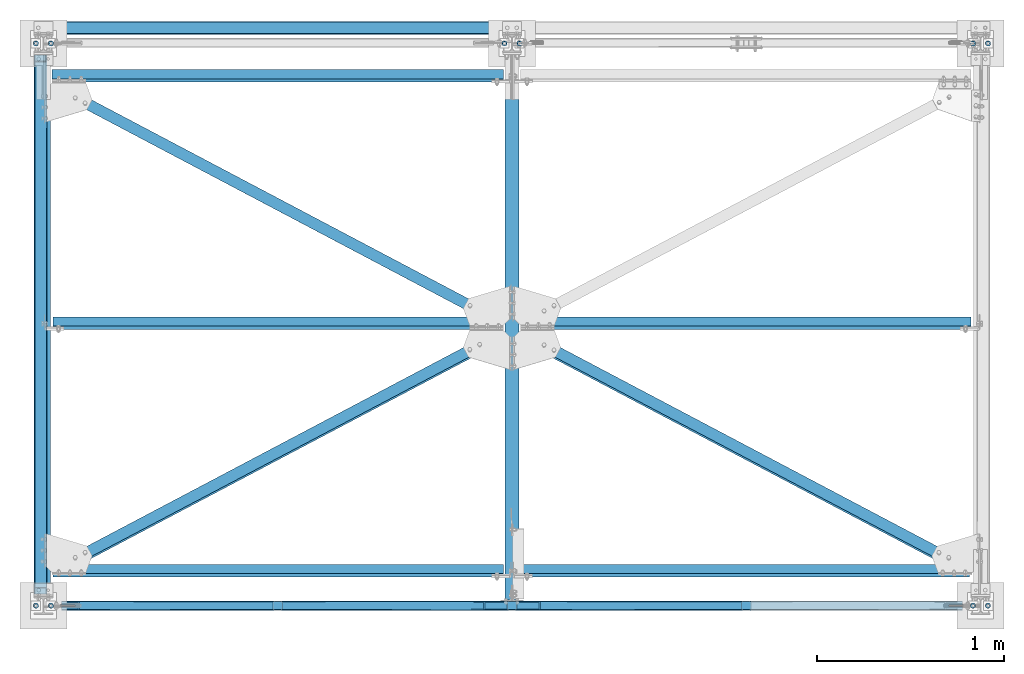
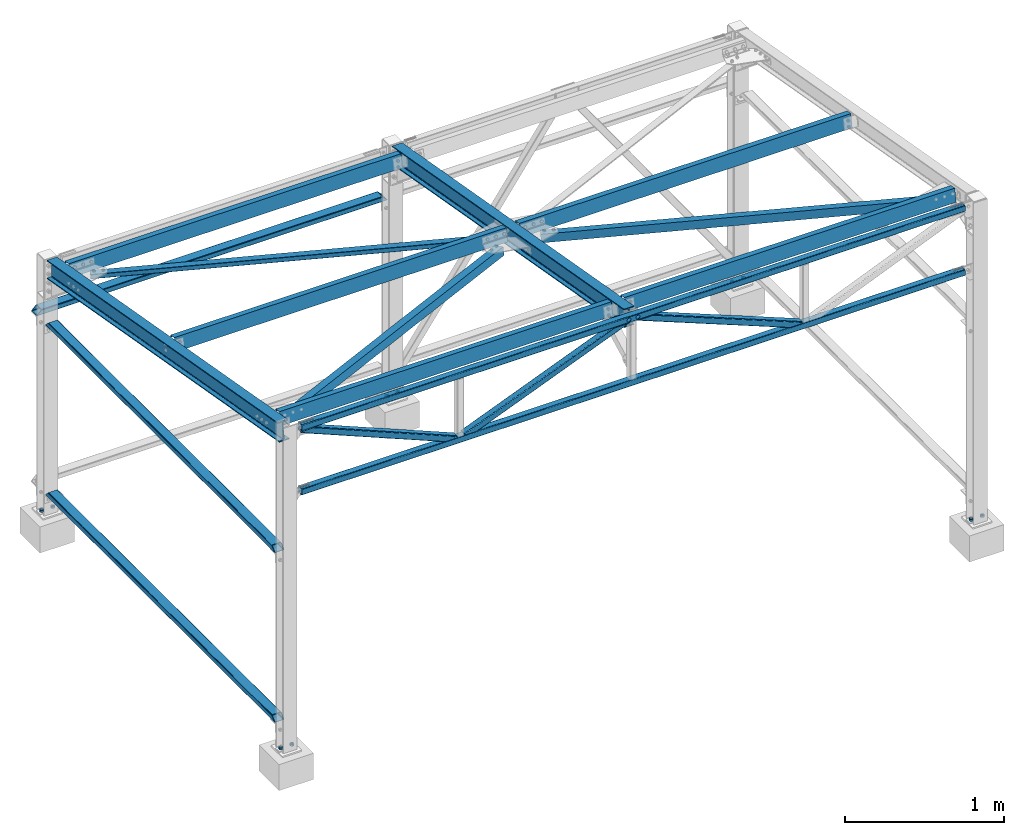
# One storey, part 5 of 28: 15 beams, 10 columns, 3 members, 24 elements without a shape of their own.
"""IFC2X3 building model written with IfcOpenShell, lengths in millimetres."""

from ifc_helpers import new_model, si_unit, frame, origin_with_axes, origin_2d_with_axis, place, context, subcontext, project, spatial, rectangle, hollow_rectangle, circle, hollow_circle, i_section, l_section, c_section, extrude, boolean, clip, halfspace, material, type_object, element, aggregate, save


model = new_model("IFC2X3")

# Units and contexts
model_context = context("Model", 3, precision=1e-05, world=origin_with_axes())
body_context = subcontext(model_context, "Body", "Model", "MODEL_VIEW")
ifc_project = project(units=[si_unit("LENGTHUNIT", "METRE", prefix="MILLI"), si_unit("AREAUNIT", "SQUARE_METRE"), si_unit("VOLUMEUNIT", "CUBIC_METRE"), si_unit("MASSUNIT", "GRAM", prefix="KILO"), si_unit("TIMEUNIT", "SECOND"), si_unit("PLANEANGLEUNIT", "RADIAN"), si_unit("SOLIDANGLEUNIT", "STERADIAN"), si_unit("THERMODYNAMICTEMPERATUREUNIT", "DEGREE_CELSIUS"), si_unit("LUMINOUSINTENSITYUNIT", "LUMEN")], contexts=[model_context])

# Site, building, storey
site_placement = place(None, origin_with_axes())
site = spatial("IfcSite", under=ifc_project, at=site_placement, CompositionType="ELEMENT")
building_placement = place(site_placement, origin_with_axes())
building = spatial("IfcBuilding", under=site, at=building_placement, Name="Undefined", CompositionType="ELEMENT")
storey_placement = place(building_placement, origin_with_axes())
storey = spatial("IfcBuildingStorey", under=building, at=storey_placement, Name="Undefined", CompositionType="ELEMENT", Elevation=0.0)

# Assembly, column
assembly_1_placement = place(storey_placement, origin_with_axes())
assembly_1 = element("IfcElementAssembly", 1, at=assembly_1_placement, inside=storey, AssemblyPlace="NOTDEFINED", PredefinedType="NOTDEFINED")
ifc_material = material(Name="STEEL/S235JR")
column_type = type_object("IfcColumnType", PredefinedType="NOTDEFINED")
column_1_placement = place(assembly_1_placement, frame((4960.00000000035, 3000.00000000094, 229.999895901093), z_axis=(0.0, 0.0, -1.0), x_axis=(0.0, -1.0, 0.0)))
column_1 = element("IfcColumn", 2, at=column_1_placement, type_object=column_type, material=ifc_material, context=body_context, shape_type="SweptSolid", body=[
    extrude(hollow_circle(Radius=14.0, WallThickness=7.0, at=origin_2d_with_axis()), frame((0.0, 0.0, 14.0), z_axis=(0.0, 0.0, -1.0), x_axis=(0.0, 1.0, 0.0)), (0.0, 0.0, 1.0), 14.0),
])
aggregate(assembly_1, [column_1])

assembly_2_placement = place(storey_placement, origin_with_axes())
assembly_2 = element("IfcElementAssembly", 3, at=assembly_2_placement, inside=storey, AssemblyPlace="NOTDEFINED", PredefinedType="NOTDEFINED")
column_2_placement = place(assembly_2_placement, frame((5040.00000000035, 3000.00000000094, 229.999895901093), z_axis=(0.0, 0.0, -1.0), x_axis=(0.0, 1.0, 0.0)))
column_2 = element("IfcColumn", 4, at=column_2_placement, type_object=column_type, material=ifc_material, context=body_context, shape_type="SweptSolid", body=[
    extrude(hollow_circle(Radius=14.0, WallThickness=7.0, at=origin_2d_with_axis()), frame((0.0, 0.0, 14.0), z_axis=(0.0, 0.0, -1.0), x_axis=(0.0, 1.0, 0.0)), (0.0, 0.0, 1.0), 14.0),
])
aggregate(assembly_2, [column_2])

assembly_3_placement = place(storey_placement, origin_with_axes())
assembly_3 = element("IfcElementAssembly", 5, at=assembly_3_placement, inside=storey, AssemblyPlace="NOTDEFINED", PredefinedType="NOTDEFINED")
column_3_placement = place(assembly_3_placement, frame((4960.00000000035, 9.38356947699504e-10, 229.999895901477), z_axis=(0.0, 0.0, -1.0), x_axis=(0.0, -1.0, 0.0)))
column_3 = element("IfcColumn", 6, at=column_3_placement, type_object=column_type, material=ifc_material, context=body_context, shape_type="SweptSolid", body=[
    extrude(hollow_circle(Radius=14.0, WallThickness=7.0, at=origin_2d_with_axis()), frame((0.0, 0.0, 14.0), z_axis=(0.0, 0.0, -1.0), x_axis=(0.0, 1.0, 0.0)), (0.0, 0.0, 1.0), 14.0),
])
aggregate(assembly_3, [column_3])

assembly_4_placement = place(storey_placement, origin_with_axes())
assembly_4 = element("IfcElementAssembly", 7, at=assembly_4_placement, inside=storey, AssemblyPlace="NOTDEFINED", PredefinedType="NOTDEFINED")
column_4_placement = place(assembly_4_placement, frame((5040.00000000035, 9.38356947699504e-10, 229.999895901477), z_axis=(0.0, 0.0, -1.0), x_axis=(0.0, 1.0, 0.0)))
column_4 = element("IfcColumn", 8, at=column_4_placement, type_object=column_type, material=ifc_material, context=body_context, shape_type="SweptSolid", body=[
    extrude(hollow_circle(Radius=14.0, WallThickness=7.0, at=origin_2d_with_axis()), frame((0.0, 0.0, 14.0), z_axis=(0.0, 0.0, -1.0), x_axis=(0.0, 1.0, 0.0)), (0.0, 0.0, 1.0), 14.0),
])
aggregate(assembly_4, [column_4])

assembly_5_placement = place(storey_placement, origin_with_axes())
assembly_5 = element("IfcElementAssembly", 9, at=assembly_5_placement, inside=storey, AssemblyPlace="NOTDEFINED", PredefinedType="NOTDEFINED")
column_5_placement = place(assembly_5_placement, frame((2459.99999999999, 3000.00000000096, 229.999895901093), z_axis=(0.0, 0.0, -1.0), x_axis=(0.0, -1.0, 0.0)))
column_5 = element("IfcColumn", 10, at=column_5_placement, type_object=column_type, material=ifc_material, context=body_context, shape_type="SweptSolid", body=[
    extrude(hollow_circle(Radius=14.0, WallThickness=7.0, at=origin_2d_with_axis()), frame((0.0, 0.0, 14.0), z_axis=(0.0, 0.0, -1.0), x_axis=(0.0, 1.0, 0.0)), (0.0, 0.0, 1.0), 14.0),
])
aggregate(assembly_5, [column_5])

assembly_6_placement = place(storey_placement, origin_with_axes())
assembly_6 = element("IfcElementAssembly", 11, at=assembly_6_placement, inside=storey, AssemblyPlace="NOTDEFINED", PredefinedType="NOTDEFINED")
column_6_placement = place(assembly_6_placement, frame((2539.99999999999, 3000.00000000096, 229.999895901093), z_axis=(0.0, 0.0, -1.0), x_axis=(0.0, 1.0, 0.0)))
column_6 = element("IfcColumn", 12, at=column_6_placement, type_object=column_type, material=ifc_material, context=body_context, shape_type="SweptSolid", body=[
    extrude(hollow_circle(Radius=14.0, WallThickness=7.0, at=origin_2d_with_axis()), frame((0.0, 0.0, 14.0), z_axis=(0.0, 0.0, -1.0), x_axis=(0.0, 1.0, 0.0)), (0.0, 0.0, 1.0), 14.0),
])
aggregate(assembly_6, [column_6])

assembly_7_placement = place(storey_placement, origin_with_axes())
assembly_7 = element("IfcElementAssembly", 13, at=assembly_7_placement, inside=storey, AssemblyPlace="NOTDEFINED", PredefinedType="NOTDEFINED")
column_7_placement = place(assembly_7_placement, frame((-40.000000000382, 3000.00000000099, 229.999895901093), z_axis=(0.0, 0.0, -1.0), x_axis=(0.0, -1.0, 0.0)))
column_7 = element("IfcColumn", 14, at=column_7_placement, type_object=column_type, material=ifc_material, context=body_context, shape_type="SweptSolid", body=[
    extrude(hollow_circle(Radius=14.0, WallThickness=7.0, at=origin_2d_with_axis()), frame((0.0, 0.0, 14.0), z_axis=(0.0, 0.0, -1.0), x_axis=(0.0, 1.0, 0.0)), (0.0, 0.0, 1.0), 14.0),
])
aggregate(assembly_7, [column_7])

assembly_8_placement = place(storey_placement, origin_with_axes())
assembly_8 = element("IfcElementAssembly", 15, at=assembly_8_placement, inside=storey, AssemblyPlace="NOTDEFINED", PredefinedType="NOTDEFINED")
column_8_placement = place(assembly_8_placement, frame((39.9999999996179, 3000.00000000099, 229.999895901093), z_axis=(0.0, 0.0, -1.0), x_axis=(0.0, 1.0, 0.0)))
column_8 = element("IfcColumn", 16, at=column_8_placement, type_object=column_type, material=ifc_material, context=body_context, shape_type="SweptSolid", body=[
    extrude(hollow_circle(Radius=14.0, WallThickness=7.0, at=origin_2d_with_axis()), frame((0.0, 0.0, 14.0), z_axis=(0.0, 0.0, -1.0), x_axis=(0.0, 1.0, 0.0)), (0.0, 0.0, 1.0), 14.0),
])
aggregate(assembly_8, [column_8])

assembly_9_placement = place(storey_placement, origin_with_axes())
assembly_9 = element("IfcElementAssembly", 17, at=assembly_9_placement, inside=storey, AssemblyPlace="NOTDEFINED", PredefinedType="NOTDEFINED")
column_9_placement = place(assembly_9_placement, frame((-40.0000000003815, 9.91491333479644e-10, 229.999895901477), z_axis=(0.0, 0.0, -1.0), x_axis=(0.0, -1.0, 0.0)))
column_9 = element("IfcColumn", 18, at=column_9_placement, type_object=column_type, material=ifc_material, context=body_context, shape_type="SweptSolid", body=[
    extrude(hollow_circle(Radius=14.0, WallThickness=7.0, at=origin_2d_with_axis()), frame((0.0, 0.0, 14.0), z_axis=(0.0, 0.0, -1.0), x_axis=(0.0, 1.0, 0.0)), (0.0, 0.0, 1.0), 14.0),
])
aggregate(assembly_9, [column_9])

assembly_10_placement = place(storey_placement, origin_with_axes())
assembly_10 = element("IfcElementAssembly", 19, at=assembly_10_placement, inside=storey, AssemblyPlace="NOTDEFINED", PredefinedType="NOTDEFINED")
column_10_placement = place(assembly_10_placement, frame((39.9999999996185, 9.91491333479644e-10, 229.999895901477), z_axis=(0.0, 0.0, -1.0), x_axis=(0.0, 1.0, 0.0)))
column_10 = element("IfcColumn", 20, at=column_10_placement, type_object=column_type, material=ifc_material, context=body_context, shape_type="SweptSolid", body=[
    extrude(hollow_circle(Radius=14.0, WallThickness=7.0, at=origin_2d_with_axis()), frame((0.0, 0.0, 14.0), z_axis=(0.0, 0.0, -1.0), x_axis=(0.0, 1.0, 0.0)), (0.0, 0.0, 1.0), 14.0),
])
aggregate(assembly_10, [column_10])

# Assembly, beam
assembly_11_placement = place(storey_placement, origin_with_axes())
assembly_11 = element("IfcElementAssembly", 21, at=assembly_11_placement, inside=storey, AssemblyPlace="NOTDEFINED", PredefinedType="NOTDEFINED")
beam_type_1 = type_object("IfcBeamType", PredefinedType="NOTDEFINED")
beam_1_placement = place(assembly_11_placement, frame((-15.0000000005639, 3000.00000000014, 1699.9998958987), z_axis=(-1.0, 0.0, 0.0), x_axis=(0.0, -1.0, 0.0)))
beam_1 = element("IfcBeam", 22, at=beam_1_placement, type_object=beam_type_1, material=ifc_material, context=body_context, shape_type="Clipping", body=[
    clip(clip(clip(clip(clip(clip(extrude(hollow_rectangle(XDim=40.0, YDim=70.0, WallThickness=3.0, InnerFilletRadius=3.0, OuterFilletRadius=6.0, at=origin_2d_with_axis()), frame((3000.0, 0.0, 0.0), z_axis=(-1.0, 0.0, 0.0), x_axis=(0.0, -1.0, 0.0)), (0.0, 0.0, 1.0), 3000.0), halfspace(frame((63.0031151709723, 20.0000000001187, -35.0000000000205), z_axis=(-1.0, 0.0, 0.0), x_axis=(0.0, 0.0, 1.0)), False)), halfspace(frame((98.0031151678131, 20.0000000001187, -35.0000000000214), z_axis=(-0.707079247150489, 0.7071343141505, 0.0), x_axis=(0.0, 0.0, 1.0)), False)), halfspace(frame((2936.99688482905, 20.0000000001187, -35.0000000000205), z_axis=(1.0, 0.0, 0.0), x_axis=(0.0, -1.0, 0.0)), False)), halfspace(frame((2901.99688483221, 20.0000000001187, -35.0000000000205), z_axis=(0.707079247150488, 0.7071343141505, 0.0), x_axis=(0.7071343141505, -0.707079247150488, 0.0)), False)), halfspace(frame((47.9999999999891, -20.0000000000048, -40.0000000000059), z_axis=(-1.0, 0.0, 0.0), x_axis=(0.0, 1.0, 0.0)), False)), halfspace(frame((2942.00000000001, 20.0000000000045, -40.0000000000068), z_axis=(1.0, 0.0, 0.0), x_axis=(0.0, -1.0, 0.0)), False)),
])
aggregate(assembly_11, [beam_1])

assembly_12_placement = place(storey_placement, origin_with_axes())
assembly_12 = element("IfcElementAssembly", 23, at=assembly_12_placement, inside=storey, AssemblyPlace="NOTDEFINED", PredefinedType="NOTDEFINED")
beam_2_placement = place(assembly_12_placement, frame((-15.0000000005484, 3000.00000000045, 399.999895898523), z_axis=(-1.0, 0.0, 0.0), x_axis=(0.0, -1.0, 0.0)))
beam_2 = element("IfcBeam", 24, at=beam_2_placement, type_object=beam_type_1, material=ifc_material, context=body_context, shape_type="Clipping", body=[
    clip(clip(clip(clip(clip(clip(extrude(hollow_rectangle(XDim=40.0, YDim=70.0, WallThickness=3.0, InnerFilletRadius=3.0, OuterFilletRadius=6.0, at=origin_2d_with_axis()), frame((3000.00109932641, 0.0, 0.0), z_axis=(-1.0, 0.0, 0.0), x_axis=(0.0, -1.0, 0.0)), (0.0, 0.0, 1.0), 3000.0), halfspace(frame((63.0031151709723, 20.0000000001187, -35.0000000000205), z_axis=(-1.0, 0.0, 0.0), x_axis=(0.0, 0.0, 1.0)), False)), halfspace(frame((98.0031151678131, 20.0000000001187, -35.0000000000214), z_axis=(-0.707079247150489, 0.7071343141505, 0.0), x_axis=(0.0, 0.0, 1.0)), False)), halfspace(frame((2936.99688482905, 20.0000000001187, -35.0000000000205), z_axis=(1.0, 0.0, 0.0), x_axis=(0.0, -1.0, 0.0)), False)), halfspace(frame((2901.99688483221, 20.0000000001187, -35.0000000000205), z_axis=(0.707079247150488, 0.7071343141505, 0.0), x_axis=(0.7071343141505, -0.707079247150488, 0.0)), False)), halfspace(frame((47.9999999999891, -20.0000000000048, -40.0000000000059), z_axis=(-1.0, 0.0, 0.0), x_axis=(0.0, 1.0, 0.0)), False)), halfspace(frame((2942.00000000001, 20.0000000000045, -40.0000000000068), z_axis=(1.0, 0.0, 0.0), x_axis=(0.0, -1.0, 0.0)), False)),
])
aggregate(assembly_12, [beam_2])

assembly_13_placement = place(storey_placement, origin_with_axes())
assembly_13 = element("IfcElementAssembly", 25, at=assembly_13_placement, inside=storey, AssemblyPlace="NOTDEFINED", PredefinedType="NOTDEFINED")
beam_3_placement = place(assembly_13_placement, frame((2499.99999999999, 3083.00000000011, 1699.99989590197), z_axis=(0.0, -1.0, 0.0), x_axis=(-1.0, 0.0, 0.0)))
beam_3 = element("IfcBeam", 26, at=beam_3_placement, type_object=beam_type_1, material=ifc_material, context=body_context, shape_type="Clipping", body=[
    clip(clip(clip(clip(extrude(hollow_rectangle(XDim=40.0, YDim=70.0, WallThickness=3.0, InnerFilletRadius=3.0, OuterFilletRadius=6.0, at=origin_2d_with_axis()), frame((2550.00000000037, 0.0, 0.0), z_axis=(-1.0, 0.0, 0.0), x_axis=(0.0, -1.0, 0.0)), (0.0, 0.0, 1.0), 2550.0), halfspace(frame((2545.00000000037, -20.000000000005, -25.0000000000159), z_axis=(1.0, 0.0, 0.0), x_axis=(0.0, 0.0, 1.0)), False)), halfspace(frame((7.5, 20.0000000000045, -35.0000000000118), z_axis=(-1.0, 0.0, 0.0), x_axis=(0.0, 0.0, 1.0)), False)), halfspace(frame((2521.71572875313, -8.28427124701284, -35.0000000001091), z_axis=(0.707106781123531, -0.707106781249564, 0.0), x_axis=(0.0, 0.0, 1.0)), False)), halfspace(frame((2.50000000003047, 20.0000000004552, -35.0000000000719), z_axis=(-0.707106781186548, -0.707106781186548, 0.0), x_axis=(0.0, 0.0, 1.0)), False)),
])
aggregate(assembly_13, [beam_3])

assembly_14_placement = place(storey_placement, origin_with_axes())
assembly_14 = element("IfcElementAssembly", 27, at=assembly_14_placement, inside=storey, AssemblyPlace="NOTDEFINED", PredefinedType="NOTDEFINED")
beam_type_2 = type_object("IfcBeamType", Name="IPE140", PredefinedType="NOTDEFINED")
beam_4_placement = place(assembly_14_placement, frame((2499.99999999999, 18.81866523973, 2616.99222695353), z_axis=(0.0, 0.17401906800386, 0.984742283021841), x_axis=(0.0, 0.984742283021841, -0.174019068003859)))
beam_4 = element("IfcBeam", 28, at=beam_4_placement, type_object=beam_type_2, material=ifc_material, context=body_context, shape_type="Clipping", body=[
    clip(clip(extrude(i_section(OverallWidth=73.0, OverallDepth=140.0, WebThickness=4.699999809, FlangeThickness=6.900000095, FilletRadius=7.0, at=origin_2d_with_axis()), frame((3027.37212178297, 0.0, 0.0), z_axis=(-1.0, 0.0, 0.0), x_axis=(0.0, -1.0, 0.0)), (0.0, 0.0, 1.0), 3027.37), halfspace(frame((24.7401476920228, 36.5, -70.0000000000005), z_axis=(-0.984742283021841, 0.0, -0.17401906800386), x_axis=(-0.17401906800386, 0.0, 0.984742283021841)), False)), halfspace(frame((2978.81254831496, 0.0, -70.0), z_axis=(-0.984742283021841, 0.0, -0.17401906800386), x_axis=(0.0, 1.0, 0.0)), True)),
])
aggregate(assembly_14, [beam_4])

assembly_15_placement = place(storey_placement, origin_with_axes())
assembly_15 = element("IfcElementAssembly", 29, at=assembly_15_placement, inside=storey, AssemblyPlace="NOTDEFINED", PredefinedType="NOTDEFINED")
beam_5_placement = place(assembly_15_placement, frame((-3.8198777474463e-10, 36.5290134789461, 2613.86253673128), z_axis=(0.0, 0.17401906800386, 0.984742283021841), x_axis=(0.0, 0.984742283021841, -0.174019068003859)))
beam_5 = element("IfcBeam", 30, at=beam_5_placement, type_object=beam_type_2, material=ifc_material, context=body_context, shape_type="Clipping", body=[
    clip(extrude(i_section(OverallWidth=73.0, OverallDepth=140.0, WebThickness=4.699999809, FlangeThickness=6.900000095, FilletRadius=7.0, at=origin_2d_with_axis()), frame((3009.3873672492, 0.0, 0.0), z_axis=(-1.0, 0.0, 0.0), x_axis=(0.0, -1.0, 0.0)), (0.0, 0.0, 1.0), 3009.39), halfspace(frame((2960.8277937812, -1.30967237054686e-13, -70.0), z_axis=(-0.984742283021841, 0.0, -0.17401906800386), x_axis=(0.0, 1.0, 0.0)), True)),
])
aggregate(assembly_15, [beam_5])

assembly_16_placement = place(storey_placement, origin_with_axes())
assembly_16 = element("IfcElementAssembly", 31, at=assembly_16_placement, inside=storey, AssemblyPlace="NOTDEFINED", PredefinedType="NOTDEFINED")
beam_type_3 = type_object("IfcBeamType", PredefinedType="NOTDEFINED")
beam_6_placement = place(assembly_16_placement, frame((2493.38616103787, 1471.95837346617, 2335.8282894625), z_axis=(-0.472417067804793, 0.867927354515411, -0.153376078091081), x_axis=(-0.88137512674611, -0.46520906186599, 0.0822095779763182)))
beam_6 = element("IfcBeam", 32, at=beam_6_placement, type_object=beam_type_3, material=ifc_material, context=body_context, shape_type="Clipping", body=[
    clip(clip(extrude(l_section(Depth=60.0, Width=60.0, Thickness=4.0, FilletRadius=8.0, EdgeRadius=4.0, at=origin_2d_with_axis()), frame((2836.47668766142, -1.38289351217352e-13, 4.15383329293286e-13), z_axis=(-1.0, 0.0, 0.0), x_axis=(0.0, -1.0, 0.0)), (0.0, 0.0, 1.0), 2836.48), halfspace(frame((2659.33265455403, -29.9999999994443, -29.9999999994507), z_axis=(1.0, 0.0, 0.0), x_axis=(0.0, 0.0, 1.0)), False)), halfspace(frame((161.613468556532, 30.0000000000819, -29.9999999998093), z_axis=(-1.0, 0.0, 0.0), x_axis=(0.0, 0.0, 1.0)), False)),
])
aggregate(assembly_16, [beam_6])

assembly_17_placement = place(storey_placement, origin_with_axes())
assembly_17 = element("IfcElementAssembly", 33, at=assembly_17_placement, inside=storey, AssemblyPlace="NOTDEFINED", PredefinedType="NOTDEFINED")
beam_7_placement = place(assembly_17_placement, frame((2506.61383895718, 1471.95837324751, 2335.828289422), z_axis=(9.84741745924111e-10, -0.174019067034142, -0.984742283193205), x_axis=(0.881375126746109, -0.465209061865992, 0.0822095779763202)))
beam_7 = element("IfcBeam", 34, at=beam_7_placement, type_object=beam_type_3, material=ifc_material, context=body_context, shape_type="Clipping", body=[
    clip(clip(extrude(l_section(Depth=60.0, Width=60.0, Thickness=4.0, FilletRadius=8.0, EdgeRadius=4.0, at=origin_2d_with_axis()), frame((2836.47668766142, -1.38289351217352e-13, 4.15383329293286e-13), z_axis=(-1.0, 0.0, 0.0), x_axis=(0.0, -1.0, 0.0)), (0.0, 0.0, 1.0), 2836.48), halfspace(frame((161.616738778611, -30.0000000506839, -29.9999998932417), z_axis=(-0.999999998517212, -5.44571059946271e-05, -5.95048929672018e-10), x_axis=(-5.44571059946277e-05, 0.999999998517212, 9.30328497242413e-10)), False)), halfspace(frame((2659.85194871686, 29.9999999090346, -30.0000003531609), z_axis=(0.999999998517216, 5.44570237767513e-05, 1.29792169711076e-10), x_axis=(5.44570237767513e-05, -0.999999998517216, 5.44137037846622e-11)), False)),
])
aggregate(assembly_17, [beam_7])

assembly_18_placement = place(storey_placement, origin_with_axes())
assembly_18 = element("IfcElementAssembly", 35, at=assembly_18_placement, inside=storey, AssemblyPlace="NOTDEFINED", PredefinedType="NOTDEFINED")
beam_8_placement = place(assembly_18_placement, frame((-6.6138389581206, 2799.56969735526, 2101.21900175785), z_axis=(-0.47241706753443, -0.867927354859761, 0.153376076975218), x_axis=(0.881375126746109, -0.465209061865992, 0.0822095779763202)))
beam_8 = element("IfcBeam", 36, at=beam_8_placement, type_object=beam_type_3, material=ifc_material, context=body_context, shape_type="Clipping", body=[
    clip(clip(extrude(l_section(Depth=60.0, Width=60.0, Thickness=4.0, FilletRadius=8.0, EdgeRadius=4.0, at=origin_2d_with_axis()), frame((2836.47668766142, -1.38289351217352e-13, 4.15383329293286e-13), z_axis=(-1.0, 0.0, 0.0), x_axis=(0.0, -1.0, 0.0)), (0.0, 0.0, 1.0), 2836.48), halfspace(frame((2674.86322309209, -30.0000000156497, -29.9999997612822), z_axis=(1.0, 0.0, 0.0), x_axis=(0.0, 0.0, 1.0)), False)), halfspace(frame((176.624738790911, 29.9999999543033, -30.0000000036725), z_axis=(-0.999999998517216, 1.2979078692278e-10, -5.44570237761829e-05), x_axis=(-5.44570237761829e-05, 8.18940862086502e-11, 0.999999998517216)), False)),
])
aggregate(assembly_18, [beam_8])

assembly_19_placement = place(storey_placement, origin_with_axes())
assembly_19 = element("IfcElementAssembly", 37, at=assembly_19_placement, inside=storey, Name="C_100", AssemblyPlace="NOTDEFINED", PredefinedType="NOTDEFINED")
beam_type_4 = type_object("IfcBeamType", Name="CC100-2-15-50", PredefinedType="NOTDEFINED")
beam_9_placement = place(assembly_19_placement, frame((2499.99999998647, 1507.27735922149, 2374.26862423111), z_axis=(0.0, 0.17401906800386, 0.984742283021841), x_axis=(-1.0, 0.0, 0.0)))
beam_9 = element("IfcBeam", 38, at=beam_9_placement, type_object=beam_type_4, material=ifc_material, Name="C_100", context=body_context, shape_type="Clipping", body=[
    clip(clip(extrude(c_section(Depth=100.0, Width=50.0, WallThickness=2.0, Girth=15.0, at=origin_2d_with_axis()), frame((2499.99999998992, 0.0, 0.0), z_axis=(-1.0, 0.0, 0.0), x_axis=(0.0, -1.0, 0.0)), (0.0, 0.0, 1.0), 2500.0), halfspace(frame((2450.00000020849, -24.9999998291134, -49.9999999991865), z_axis=(1.0, 0.0, 0.0), x_axis=(0.0, 0.0, 1.0)), False)), halfspace(frame((46.4999999864881, 25.0000001715182, -49.9999999999281), z_axis=(-1.0, 0.0, 0.0), x_axis=(0.0, 0.0, 1.0)), False)),
])
aggregate(assembly_19, [beam_9])

assembly_20_placement = place(storey_placement, origin_with_axes())
assembly_20 = element("IfcElementAssembly", 39, at=assembly_20_placement, inside=storey, Name="C_100", AssemblyPlace="NOTDEFINED", PredefinedType="NOTDEFINED")
beam_10_placement = place(assembly_20_placement, frame((2499.99999998647, 1507.27735922149, 2374.26862423111), z_axis=(9.84741745924111e-10, -0.174019067034142, -0.984742283193205), x_axis=(1.0, 0.0, 0.0)))
beam_10 = element("IfcBeam", 40, at=beam_10_placement, type_object=beam_type_4, material=ifc_material, Name="C_100", context=body_context, shape_type="Clipping", body=[
    clip(clip(extrude(c_section(Depth=100.0, Width=50.0, WallThickness=2.0, Girth=15.0, at=origin_2d_with_axis()), frame((2499.99999998992, 0.0, 0.0), z_axis=(-1.0, 0.0, 0.0), x_axis=(0.0, -1.0, 0.0)), (0.0, 0.0, 1.0), 2500.0), halfspace(frame((46.4999999864881, 25.0000001715182, -49.9999999999281), z_axis=(-1.0, 0.0, 0.0), x_axis=(0.0, 0.0, 1.0)), False)), halfspace(frame((2450.00000020849, -24.9999998291134, -49.9999999991865), z_axis=(1.0, 0.0, 0.0), x_axis=(0.0, 0.0, 1.0)), False)),
])
aggregate(assembly_20, [beam_10])

assembly_21_placement = place(storey_placement, origin_with_axes())
assembly_21 = element("IfcElementAssembly", 41, at=assembly_21_placement, inside=storey, Name="C_100", AssemblyPlace="NOTDEFINED", PredefinedType="NOTDEFINED")
beam_11_placement = place(assembly_21_placement, frame((-3.44971340382472e-09, 187.722700146906, 2607.45417532634), z_axis=(9.84741745924111e-10, -0.174019067034142, -0.984742283193205), x_axis=(1.0, 0.0, 0.0)))
beam_11 = element("IfcBeam", 42, at=beam_11_placement, type_object=beam_type_4, material=ifc_material, Name="C_100", context=body_context, shape_type="Clipping", body=[
    clip(clip(extrude(c_section(Depth=100.0, Width=50.0, WallThickness=2.0, Girth=15.0, at=origin_2d_with_axis()), frame((2499.99999998992, 0.0, 0.0), z_axis=(-1.0, 0.0, 0.0), x_axis=(0.0, -1.0, 0.0)), (0.0, 0.0, 1.0), 2500.0), halfspace(frame((2453.50229640998, 23.9085399424793, 50.0000002788415), z_axis=(1.0, 0.0, 0.0), x_axis=(0.0, 0.0, -1.0)), False)), halfspace(frame((49.9999998278904, 24.999999999248, -50.0000000005607), z_axis=(-1.0, 0.0, 0.0), x_axis=(0.0, 0.0, 1.0)), False)),
])
aggregate(assembly_21, [beam_11])

assembly_22_placement = place(storey_placement, origin_with_axes())
assembly_22 = element("IfcElementAssembly", 43, at=assembly_22_placement, inside=storey, Name="C_100", AssemblyPlace="NOTDEFINED", PredefinedType="NOTDEFINED")
beam_12_placement = place(assembly_22_placement, frame((2499.99999998821, 2826.82759378073, 2141.08102026941), z_axis=(0.0, 0.173991930057882, 0.984747078327594), x_axis=(-1.0, 0.0, 0.0)))
beam_12 = element("IfcBeam", 44, at=beam_12_placement, type_object=beam_type_4, material=ifc_material, Name="C_100", context=body_context, shape_type="Clipping", body=[
    clip(clip(extrude(c_section(Depth=100.0, Width=50.0, WallThickness=2.0, Girth=15.0, at=origin_2d_with_axis()), frame((2499.99999998992, 0.0, 0.0), z_axis=(-1.0, 0.0, 0.0), x_axis=(0.0, -1.0, 0.0)), (0.0, 0.0, 1.0), 2500.0), halfspace(frame((2453.50000618526, 23.9031616679849, 50.0034496281282), z_axis=(1.0, 0.0, 0.0), x_axis=(0.0, 2.75583575168385e-05, -0.999999999620269)), False)), halfspace(frame((46.4999937914527, 22.9946218507644, 50.003424866246), z_axis=(-1.0, 0.0, 0.0), x_axis=(0.0, 2.75583575168385e-05, -0.999999999620269)), False)),
])
aggregate(assembly_22, [beam_12])

assembly_23_placement = place(storey_placement, origin_with_axes())
assembly_23 = element("IfcElementAssembly", 45, at=assembly_23_placement, inside=storey, Name="C_100", AssemblyPlace="NOTDEFINED", PredefinedType="NOTDEFINED")
beam_13_placement = place(assembly_23_placement, frame((2500.00000000001, 186.608087478006, 2607.65114448381), z_axis=(9.84741745924111e-10, -0.174019067034142, -0.984742283193205), x_axis=(1.0, 0.0, 0.0)))
beam_13 = element("IfcBeam", 46, at=beam_13_placement, type_object=beam_type_4, material=ifc_material, Name="C_100", context=body_context, shape_type="Clipping", body=[
    clip(clip(extrude(c_section(Depth=100.0, Width=50.0, WallThickness=2.0, Girth=15.0, at=origin_2d_with_axis()), frame((2499.99999998992, 0.0, 0.0), z_axis=(-1.0, 0.0, 0.0), x_axis=(0.0, -1.0, 0.0)), (0.0, 0.0, 1.0), 2500.0), halfspace(frame((2439.99999996962, 22.9595769071056, -50.0000003607574), z_axis=(1.0, 0.0, 0.0), x_axis=(0.0, 0.0, 1.0)), False)), halfspace(frame((46.4999938050282, 22.7766571679481, -49.9999997123455), z_axis=(-1.0, 0.0, 0.0), x_axis=(0.0, 0.0, 1.0)), False)),
])
aggregate(assembly_23, [beam_13])

# Assembly, members, beams
assembly_24_placement = place(storey_placement, origin_with_axes())
assembly_24 = element("IfcElementAssembly", 47, at=assembly_24_placement, inside=storey, Name="TREILLIS", AssemblyPlace="NOTDEFINED", PredefinedType="NOTDEFINED")
member_type = type_object("IfcMemberType", PredefinedType="NOTDEFINED")
member_1_placement = place(assembly_24_placement, frame((1249.82577339288, -0.000311427450608193, 2145.13439692566), z_axis=(0.383566084023106, 0.0, 0.923513432055636), x_axis=(-0.923513432055636, 0.0, 0.383566084023107)))
solid = boolean("DIFFERENCE", boolean("DIFFERENCE", boolean("DIFFERENCE", boolean("DIFFERENCE", boolean("DIFFERENCE", boolean("DIFFERENCE", boolean("DIFFERENCE", boolean("DIFFERENCE", extrude(hollow_rectangle(XDim=50.0, YDim=50.0, WallThickness=3.2, InnerFilletRadius=6.4, OuterFilletRadius=9.6, at=origin_2d_with_axis()), frame((1279.9768198639, 0.0, -7.10529868199696e-14), z_axis=(-1.0, 0.0, 0.0), x_axis=(0.0, -1.0, 0.0)), (0.0, 0.0, 1.0), 1279.98), extrude(rectangle(XDim=6.0, YDim=100.0, at=origin_2d_with_axis()), frame((1152.44502361571, -0.000311426983596874, 31.2141404578141), z_axis=(0.923513432055635, 0.0, -0.383566084023107), x_axis=(0.0, 1.0, 0.0)), (0.0, 0.0, 1.0), 154.0)), extrude(rectangle(XDim=6.0, YDim=80.0, at=origin_2d_with_axis()), frame((1183.98608741778, -0.000311426983596874, 28.942292257609), z_axis=(0.923513432055635, 0.0, -0.383566084023107), x_axis=(0.0, 1.0, 0.0)), (0.0, 0.0, 1.0), 124.0)), halfspace(frame((1237.37953518363, -25.0, -25.0), z_axis=(0.923513432055635, 0.0, -0.383566084023107), x_axis=(0.383566084023106, 0.0, 0.923513432055636)), False)), halfspace(frame((16.3504774343324, 25.0, -25.8042545245135), z_axis=(-0.923459302071662, 0.0, 0.383696387026668), x_axis=(0.383696387026668, 0.0, 0.923459302071662)), False)), halfspace(frame((-1.18533799155978, -25.0000000000007, -24.971883666351), z_axis=(0.0, -1.0, 0.0), x_axis=(0.0474135196623932, 0.0, 0.998875346654038)), False)), halfspace(frame((-1.18533799155978, -25.0000000000007, -24.971883666351), z_axis=(0.0, -1.0, 0.0), x_axis=(0.0474135196623932, 0.0, 0.998875346654038)), False)), halfspace(frame((-1.18533799155978, -25.0000000000007, -24.971883666351), z_axis=(0.0, -1.0, 0.0), x_axis=(0.0474135196623932, 0.0, 0.998875346654038)), False)), halfspace(frame((131.213829122497, 24.9999956499896, -27.4858880891647), z_axis=(-0.383566084023107, 0.0, -0.923513432055636), x_axis=(-0.923513432055636, 0.0, 0.383566084023107)), False))
member_1 = element("IfcMember", 48, at=member_1_placement, type_object=member_type, material=ifc_material, Name="TREILLIS", context=body_context, shape_type="CSG", body=[
    boolean("DIFFERENCE", solid, halfspace(frame((1337.29765165405, -25.0000043500104, -50.9754585506839), z_axis=(0.383566084023106, 0.0, 0.923513432055636), x_axis=(-0.923513432055636, 0.0, 0.383566084023107)), False)),
])
member_2_placement = place(assembly_24_placement, frame((3749.80114309124, 0.000860389832237018, 2145.07998469004), z_axis=(0.371395225142611, -4.59060312952176e-12, 0.928474871356931), x_axis=(-0.92847487135693, 1.86767842669232e-11, 0.371395225142613)))
member_2 = element("IfcMember", 49, at=member_2_placement, type_object=member_type, material=ifc_material, Name="TREILLIS", context=body_context, shape_type="Clipping", body=[
    clip(clip(clip(clip(extrude(hollow_rectangle(XDim=50.0, YDim=50.0, WallThickness=3.2, InnerFilletRadius=6.4, OuterFilletRadius=9.6, at=origin_2d_with_axis()), frame((1346.27472150682, -6.55680052058621e-20, 5.29480610550849e-13), z_axis=(-1.0, 0.0, 0.0), x_axis=(0.0, -1.0, 0.0)), (0.0, 0.0, 1.0), 1346.27), halfspace(frame((1309.41191767647, -25.0, -25.0), z_axis=(0.928474871356523, -9.3701868032885e-07, -0.371395225142448), x_axis=(0.371395225142611, -4.59060312952176e-12, 0.928474871356931)), False)), halfspace(frame((16.9054774640185, 25.0, -24.9999999999995), z_axis=(-0.928524635178635, 9.37068926934537e-07, 0.371270793175956), x_axis=(0.37127079317612, 1.20983034103519e-10, 0.928524635179043)), False)), halfspace(frame((129.812847661196, 25.0, -25.0), z_axis=(-0.371395225142613, 4.58373687087631e-12, -0.92847487135693), x_axis=(-0.92847487135693, 1.86767842669232e-11, 0.371395225142613)), False)), halfspace(frame((1317.03073005749, -25.0000041803107, -25.003417732994), z_axis=(0.371395225142611, -4.59060312952176e-12, 0.928474871356931), x_axis=(-0.92847487135693, 1.86767842669232e-11, 0.371395225142613)), False)),
])
member_3_placement = place(assembly_24_placement, frame((1249.9425515134, -0.000311427450608193, 2145.13439692566), z_axis=(-0.371368997977013, 0.0, 0.928485361942529), x_axis=(0.928485361942529, 0.0, 0.371368997977013)))
member_3 = element("IfcMember", 50, at=member_3_placement, type_object=member_type, material=ifc_material, Name="TREILLIS", context=body_context, shape_type="Clipping", body=[
    clip(clip(clip(clip(extrude(hollow_rectangle(XDim=50.0, YDim=50.0, WallThickness=3.2, InnerFilletRadius=6.4, OuterFilletRadius=9.6, at=origin_2d_with_axis()), frame((1346.22328070256, -1.0842021724855e-19, 7.47304041261199e-14), z_axis=(-1.0, 0.0, 0.0), x_axis=(0.0, -1.0, 0.0)), (0.0, 0.0, 1.0), 1346.22), halfspace(frame((1309.15732239681, -25.0, -24.9999999999998), z_axis=(0.928485361942529, 0.0, -0.371368997977012), x_axis=(0.371368997977012, 0.0, 0.928485361942529)), False)), halfspace(frame((16.803056719672, 25.0, -24.9999999999998), z_axis=(-0.928537752494202, 0.0, 0.371237985924145), x_axis=(0.371237985924145, 0.0, 0.928537752494202)), False)), halfspace(frame((1192.30578853934, 25.0000043500104, 24.8620626505742), z_axis=(0.371368997977012, 0.0, 0.928485361942529), x_axis=(0.928485361942529, 0.0, -0.371368997977012)), False)), halfspace(frame((129.844357624462, 25.0000043500104, -25.0672570339718), z_axis=(-0.371368997977013, 0.0, -0.928485361942529), x_axis=(-0.928485361942529, 0.0, 0.371368997977013)), False)),
])
beam_type_5 = type_object("IfcBeamType", PredefinedType="NOTDEFINED")
beam_14_placement = place(assembly_24_placement, frame((4999.81889432251, -0.000311423304747649, 2145.07998468953), z_axis=(0.0, 0.0, 1.0), x_axis=(-1.0, 0.0, 0.0)))
beam_14 = element("IfcBeam", 51, at=beam_14_placement, type_object=beam_type_5, material=ifc_material, Name="TREILLIS", context=body_context, shape_type="CSG", body=[
    boolean("DIFFERENCE", boolean("DIFFERENCE", boolean("DIFFERENCE", boolean("DIFFERENCE", extrude(hollow_rectangle(XDim=50.0, YDim=50.0, WallThickness=3.2, InnerFilletRadius=6.4, OuterFilletRadius=9.6, at=origin_2d_with_axis()), frame((5000.0, 0.0, 0.0), z_axis=(-1.0, 0.0, 0.0), x_axis=(0.0, -1.0, 0.0)), (0.0, 0.0, 1.0), 5000.0), extrude(rectangle(XDim=6.0, YDim=60.0, at=origin_2d_with_axis()), frame((167.318894322155, -4.21590584664955e-09, 1.54614099301398e-09), z_axis=(-1.0, 0.0, 0.0), x_axis=(0.0, -1.0, 0.0)), (0.0, 0.0, 1.0), 124.0)), extrude(rectangle(XDim=6.0, YDim=60.0, at=origin_2d_with_axis()), frame((4832.31889432252, -4.34579451891182e-06, -3.60612431698928), z_axis=(1.0, 0.0, 0.0), x_axis=(0.0, 1.0, 0.0)), (0.0, 0.0, 1.0), 124.0)), halfspace(frame((97.3188943221585, 25.0000000000009, -24.9999999997162), z_axis=(-1.0, 0.0, 0.0), x_axis=(0.0, 0.0, 1.0)), False)), halfspace(frame((4902.31889432306, -25.0000043500638, -24.9999999997408), z_axis=(1.0, 0.0, 0.0), x_axis=(0.0, 0.0, 1.0)), False)),
])
beam_15_placement = place(assembly_24_placement, frame((5037.50000000036, 3.75511532979544e-09, 2635.99989966715), z_axis=(0.0, 0.0, 1.0), x_axis=(-1.0, 0.0, 0.0)))
beam_15 = element("IfcBeam", 52, at=beam_15_placement, type_object=beam_type_5, material=ifc_material, Name="TREILLIS", context=body_context, shape_type="CSG", body=[
    boolean("DIFFERENCE", boolean("DIFFERENCE", boolean("DIFFERENCE", boolean("DIFFERENCE", boolean("DIFFERENCE", boolean("DIFFERENCE", boolean("DIFFERENCE", extrude(hollow_rectangle(XDim=50.0, YDim=50.0, WallThickness=3.2, InnerFilletRadius=6.4, OuterFilletRadius=9.6, at=origin_2d_with_axis()), frame((4940.01293692727, 0.0, 0.0), z_axis=(-1.0, 0.0, 0.0), x_axis=(0.0, -1.0, 0.0)), (0.0, 0.0, 1.0), 4940.01), extrude(rectangle(XDim=6.0, YDim=100.0, at=origin_2d_with_axis()), frame((4844.05576610969, 4.22212664830113e-09, -19.9999999984316), z_axis=(1.0, 0.0, 0.0), x_axis=(0.0, 1.0, 0.0)), (0.0, 0.0, 1.0), 149.94)), extrude(rectangle(XDim=6.0, YDim=100.0, at=origin_2d_with_axis()), frame((230.944233891028, 4.22212664830113e-09, -19.9999999984316), z_axis=(-1.0, 0.0, 0.0), x_axis=(0.0, -1.0, 0.0)), (0.0, 0.0, 1.0), 149.94)), extrude(circle(Radius=15.0, at=origin_2d_with_axis()), frame((2504.99000000036, -4.99999999624507, -0.00323436009239231), z_axis=(0.0, 1.0, 0.0), x_axis=(0.0, 0.0, -1.0)), (0.0, 0.0, 1.0), 49.0)), extrude(circle(Radius=15.0, at=origin_2d_with_axis()), frame((2569.85000000036, -4.99999999624507, -0.00323436009239231), z_axis=(0.0, 1.0, 0.0), x_axis=(0.0, 0.0, -1.0)), (0.0, 0.0, 1.0), 49.0)), extrude(rectangle(XDim=7.0, YDim=60.0, at=origin_2d_with_axis()), frame((4840.00000000071, 4.16289580584817e-09, 1.26237864606082e-09), z_axis=(1.0, 0.0, 0.0), x_axis=(0.0, 1.0, 0.0)), (0.0, 0.0, 1.0), 154.0)), halfspace(frame((134.999999999836, 25.0000000000532, -24.9999999996967), z_axis=(-1.0, 0.0, 0.0), x_axis=(0.0, 0.0, 1.0)), False)), halfspace(frame((4940.00000000091, -25.0000000000017, -24.9999999997035), z_axis=(1.0, 0.0, 0.0), x_axis=(0.0, 0.0, 1.0)), False)),
])
aggregate(assembly_24, [member_1, member_2, member_3, beam_14, beam_15])

save(model, "model.ifc")
